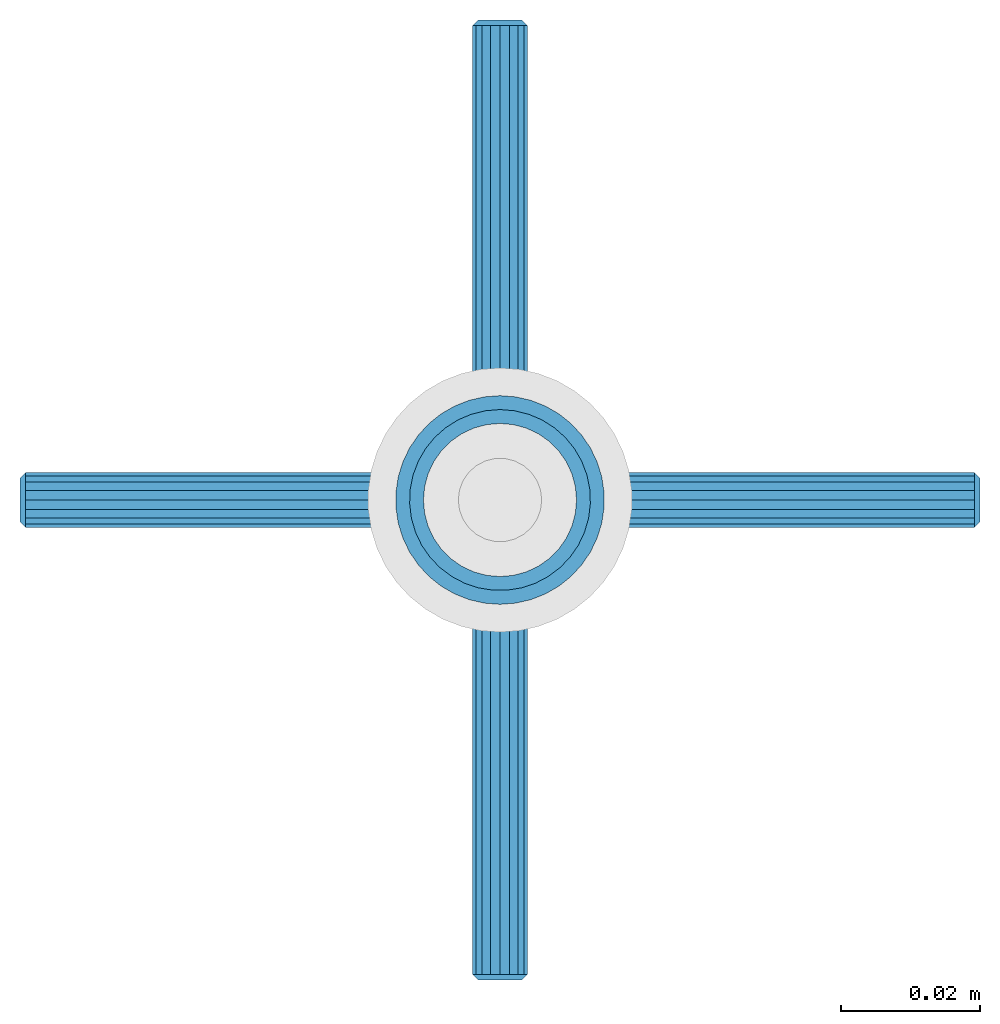
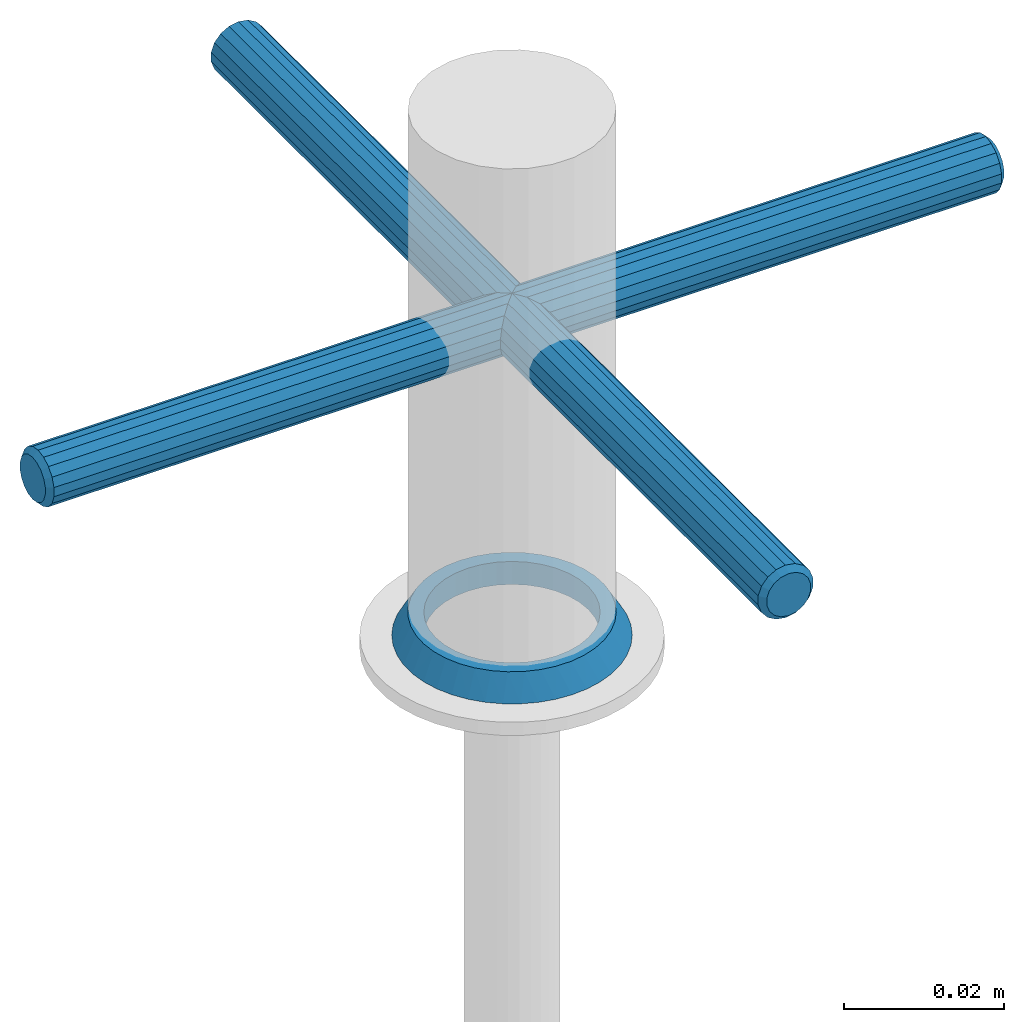
# One storey, part 3 of 3: 2 mechanical fasteners, 1 member, 2 elements without a shape of their own.
"""IFC4 building model written with IfcOpenShell, lengths in metres."""

from ifc_helpers import new_model, si_unit, direction, frame, origin_with_axes, place, context, subcontext, project, spatial, triangles, material, element, aggregate, save


model = new_model("IFC4")

# Units and contexts
model_context = context("Model", 3, precision=1e-05, world=origin_with_axes(), true_north=direction((0.0, 1.0)))
body_context = subcontext(model_context, "Body", "Model", "MODEL_VIEW")
ifc_project = project(units=[si_unit("LENGTHUNIT", "METRE"), si_unit("PLANEANGLEUNIT", "RADIAN"), si_unit("MASSUNIT", "GRAM", prefix="KILO"), si_unit("AREAUNIT", "SQUARE_METRE"), si_unit("TIMEUNIT", "SECOND"), si_unit("VOLUMEUNIT", "CUBIC_METRE")], contexts=[model_context])

# Site, building, storey
site_placement = place(None, origin_with_axes())
site = spatial("IfcSite", under=ifc_project, at=site_placement, CompositionType="ELEMENT")
building_placement = place(site_placement, origin_with_axes())
building = spatial("IfcBuilding", under=site, at=building_placement, CompositionType="ELEMENT")
storey_placement = place(building_placement, origin_with_axes())
storey = spatial("IfcBuildingStorey", under=building, at=storey_placement, Name="Geschoss 1", CompositionType="ELEMENT", Elevation=0.0)

# Member
ifc_material_1 = material()
member_placement = place(storey_placement, frame((8.149333, 6.0175, 0.02), z_axis=(0.0, 1.0, 0.0), x_axis=(0.0, 0.0, 1.0)))
element("IfcMember", 1, at=member_placement, inside=storey, material=ifc_material_1, PredefinedType="STUD", context=body_context, shape_type="Tessellation", body=[
    triangles([(0.0, -0.00191, -0.010833), (0.0035, 0.0, -0.011), (0.0, 0.0, -0.011), (0.0035, 0.00191, -0.010833), (0.0, 0.00191, -0.010833), (0.0035, 0.003762, -0.010337), (0.0, 0.003762, -0.010337), (0.0035, 0.0055, -0.009526), (0.0, 0.0055, -0.009526), (0.0035, 0.007071, -0.008426), (0.0, 0.007071, -0.008426), (0.0035, 0.008426, -0.007071), (0.0, 0.008426, -0.007071), (0.0035, 0.009526, -0.0055), (0.0, 0.009526, -0.0055), (0.0035, 0.010337, -0.003762), (0.0, 0.010337, -0.003762), (0.0035, 0.010833, -0.00191), (0.0, 0.010833, -0.00191), (0.0035, 0.011, 0.0), (0.0, 0.011, 0.0), (0.0035, 0.010833, 0.00191), (0.0, 0.010833, 0.00191), (0.0035, 0.010337, 0.003762), (0.0, 0.010337, 0.003762), (0.0035, 0.009526, 0.0055), (0.0, 0.009526, 0.0055), (0.0035, 0.008426, 0.007071), (0.0, 0.008426, 0.007071), (0.0035, 0.007071, 0.008426), (0.0, 0.007071, 0.008426), (0.0035, 0.0055, 0.009526), (0.0, 0.0055, 0.009526), (0.0035, 0.003762, 0.010337), (0.0, 0.003762, 0.010337), (0.0035, 0.00191, 0.010833), (0.0, 0.00191, 0.010833), (0.0035, 0.0, 0.011), (0.0, 0.0, 0.011), (0.0035, -0.00191, 0.010833), (0.0, -0.00191, 0.010833), (0.0035, -0.003762, 0.010337), (0.0, -0.003762, 0.010337), (0.0035, -0.0055, 0.009526), (0.0, -0.0055, 0.009526), (0.0035, -0.007071, 0.008426), (0.0, -0.007071, 0.008426), (0.0035, -0.008426, 0.007071), (0.0, -0.008426, 0.007071), (0.0035, -0.009526, 0.0055), (0.0, -0.009526, 0.0055), (0.0035, -0.010337, 0.003762), (0.0, -0.010337, 0.003762), (0.0035, -0.010833, 0.00191), (0.0, -0.010833, 0.00191), (0.0035, -0.011, 0.0), (0.0, -0.011, 0.0), (0.0035, -0.010833, -0.00191), (0.0, -0.010833, -0.00191), (0.0035, -0.010337, -0.003762), (0.0, -0.010337, -0.003762), (0.0035, -0.009526, -0.0055), (0.0, -0.009526, -0.0055), (0.0035, -0.008426, -0.007071), (0.0, -0.008426, -0.007071), (0.0035, -0.007071, -0.008426), (0.0, -0.007071, -0.008426), (0.0035, -0.0055, -0.009526), (0.0, -0.0055, -0.009526), (0.0035, -0.003762, -0.010337), (0.0, -0.003762, -0.010337), (0.0035, -0.00191, -0.010833), (0.0, 0.011727, -0.009352), (0.0, 0.01299, -0.0075), (0.0035, 0.011258, -0.0065), (0.0, 0.013963, -0.00548), (0.0035, 0.012155, -0.00461), (0.0, 0.014624, -0.003338), (0.0035, 0.012737, -0.0026), (0.0, 0.014958, -0.001121), (0.0035, 0.012989, -0.000523), (0.0, 0.014958, 0.001121), (0.0035, 0.012905, 0.001567), (0.0, 0.014624, 0.003338), (0.0035, 0.012487, 0.003617), (0.0, 0.013963, 0.00548), (0.0035, 0.011745, 0.005573), (0.0, 0.01299, 0.0075), (0.0035, 0.010699, 0.007385), (0.0, 0.011727, 0.009352), (0.0035, 0.009376, 0.009005), (0.0, 0.010203, 0.010996), (0.0035, 0.00781, 0.010393), (0.0, 0.00845, 0.012394), (0.0035, 0.006041, 0.011511), (0.0, 0.006508, 0.013515), (0.0035, 0.004117, 0.012331), (0.0, 0.004421, 0.014334), (0.0035, 0.002085, 0.012832), (0.0, 0.002236, 0.014832), (0.0035, 0.0, 0.013), (0.0, 0.0, 0.015), (0.0, -0.002236, 0.014832), (0.0035, 0.01007, -0.008222), (0.0, 0.010203, -0.010996), (0.0035, 0.008621, -0.009731), (0.0, 0.00845, -0.012394), (0.0035, 0.006948, -0.010987), (0.0, 0.006508, -0.013515), (0.0035, 0.005096, -0.01196), (0.0, 0.004421, -0.014334), (0.0035, 0.003111, -0.012622), (0.0, 0.002236, -0.014832), (0.0035, 0.001046, -0.012958), (0.0, 0.0, -0.015), (0.0035, -0.001046, -0.012958), (0.0, -0.002236, -0.014832), (0.0035, -0.003111, -0.012622), (0.0, -0.004421, -0.014334), (0.0035, -0.005096, -0.01196), (0.0, -0.006508, -0.013515), (0.0035, -0.006948, -0.010987), (0.0, -0.00845, -0.012394), (0.0035, -0.008621, -0.009731), (0.0, -0.010203, -0.010996), (0.0035, -0.01007, -0.008222), (0.0, -0.011727, -0.009352), (0.0035, -0.011258, -0.0065), (0.0, -0.01299, -0.0075), (0.0, -0.013963, -0.00548), (0.0035, -0.012155, -0.00461), (0.0, -0.014624, -0.003338), (0.0035, -0.012737, -0.0026), (0.0, -0.014958, -0.001121), (0.0035, -0.012989, -0.000523), (0.0, -0.014958, 0.001121), (0.0035, -0.012905, 0.001567), (0.0, -0.014624, 0.003338), (0.0035, -0.012487, 0.003617), (0.0, -0.013963, 0.00548), (0.0035, -0.011745, 0.005573), (0.0, -0.01299, 0.0075), (0.0035, -0.010699, 0.007385), (0.0, -0.011727, 0.009352), (0.0035, -0.009376, 0.009005), (0.0, -0.010203, 0.010996), (0.0035, -0.00781, 0.010393), (0.0, -0.00845, 0.012394), (0.0035, -0.006041, 0.011511), (0.0, -0.006508, 0.013515), (0.0035, -0.004117, 0.012331), (0.0, -0.004421, 0.014334), (0.0035, -0.002085, 0.012832)], [[1, 2, 3], [3, 2, 4], [3, 4, 5], [5, 4, 6], [5, 6, 7], [7, 6, 8], [7, 8, 9], [9, 8, 10], [9, 10, 11], [11, 10, 12], [11, 12, 13], [13, 12, 14], [13, 14, 15], [15, 14, 16], [15, 16, 17], [17, 16, 18], [17, 18, 19], [19, 18, 20], [19, 20, 21], [21, 20, 22], [21, 22, 23], [23, 22, 24], [23, 24, 25], [25, 24, 26], [25, 26, 27], [27, 26, 28], [27, 28, 29], [29, 28, 30], [29, 30, 31], [31, 30, 32], [31, 32, 33], [33, 32, 34], [33, 34, 35], [35, 34, 36], [35, 36, 37], [37, 36, 38], [37, 38, 39], [39, 38, 40], [39, 40, 41], [41, 40, 42], [41, 42, 43], [43, 42, 44], [43, 44, 45], [45, 44, 46], [45, 46, 47], [47, 46, 48], [47, 48, 49], [49, 48, 50], [49, 50, 51], [51, 50, 52], [51, 52, 53], [53, 52, 54], [53, 54, 55], [55, 54, 56], [55, 56, 57], [57, 56, 58], [57, 58, 59], [59, 58, 60], [59, 60, 61], [61, 60, 62], [61, 62, 63], [63, 62, 64], [63, 64, 65], [65, 64, 66], [65, 66, 67], [67, 66, 68], [67, 68, 69], [69, 68, 70], [69, 70, 71], [71, 70, 72], [71, 72, 1], [1, 72, 2], [73, 74, 75], [75, 74, 76], [75, 76, 77], [77, 76, 78], [77, 78, 79], [79, 78, 80], [79, 80, 81], [81, 80, 82], [81, 82, 83], [83, 82, 84], [83, 84, 85], [85, 84, 86], [85, 86, 87], [87, 86, 88], [87, 88, 89], [89, 88, 90], [89, 90, 91], [91, 90, 92], [91, 92, 93], [93, 92, 94], [93, 94, 95], [95, 94, 96], [95, 96, 97], [97, 96, 98], [97, 98, 99], [99, 98, 100], [99, 100, 101], [101, 100, 102], [101, 102, 103], [75, 104, 73], [73, 104, 105], [104, 106, 105], [105, 106, 107], [106, 108, 107], [107, 108, 109], [108, 110, 109], [109, 110, 111], [110, 112, 111], [111, 112, 113], [112, 114, 113], [113, 114, 115], [114, 116, 115], [115, 116, 117], [116, 118, 117], [117, 118, 119], [118, 120, 119], [119, 120, 121], [120, 122, 121], [121, 122, 123], [122, 124, 123], [123, 124, 125], [124, 126, 125], [125, 126, 127], [126, 128, 127], [127, 128, 129], [129, 128, 130], [130, 128, 131], [130, 131, 132], [132, 131, 133], [132, 133, 134], [134, 133, 135], [134, 135, 136], [136, 135, 137], [136, 137, 138], [138, 137, 139], [138, 139, 140], [140, 139, 141], [140, 141, 142], [142, 141, 143], [142, 143, 144], [144, 143, 145], [144, 145, 146], [146, 145, 147], [146, 147, 148], [148, 147, 149], [148, 149, 150], [150, 149, 151], [150, 151, 152], [152, 151, 153], [152, 153, 103], [103, 153, 101], [131, 128, 62], [62, 128, 126], [62, 126, 64], [64, 126, 124], [64, 124, 66], [66, 124, 122], [66, 122, 68], [68, 122, 120], [68, 120, 70], [70, 120, 118], [70, 118, 72], [72, 118, 116], [72, 116, 2], [2, 116, 114], [2, 114, 4], [4, 114, 112], [4, 112, 6], [6, 112, 110], [6, 110, 8], [8, 110, 108], [8, 108, 10], [10, 108, 106], [10, 106, 12], [12, 106, 104], [12, 104, 14], [14, 104, 75], [14, 75, 77], [62, 60, 131], [131, 60, 133], [60, 58, 133], [133, 58, 135], [58, 56, 135], [135, 56, 137], [56, 54, 137], [137, 54, 139], [54, 52, 139], [139, 52, 141], [52, 50, 141], [141, 50, 143], [50, 48, 143], [143, 48, 145], [48, 46, 145], [145, 46, 147], [46, 44, 147], [147, 44, 149], [44, 42, 149], [149, 42, 151], [42, 40, 151], [151, 40, 153], [40, 38, 153], [153, 38, 101], [101, 38, 99], [99, 38, 36], [99, 36, 97], [97, 36, 34], [97, 34, 95], [95, 34, 32], [95, 32, 93], [93, 32, 30], [93, 30, 91], [91, 30, 28], [91, 28, 89], [89, 28, 26], [89, 26, 87], [87, 26, 24], [87, 24, 85], [85, 24, 22], [85, 22, 83], [83, 22, 20], [83, 20, 81], [81, 20, 18], [81, 18, 79], [79, 18, 16], [79, 16, 77], [77, 16, 14], [76, 74, 15], [15, 74, 73], [15, 73, 13], [13, 73, 105], [13, 105, 11], [11, 105, 107], [11, 107, 9], [9, 107, 109], [9, 109, 7], [7, 109, 111], [7, 111, 5], [5, 111, 113], [5, 113, 3], [3, 113, 115], [3, 115, 117], [15, 17, 76], [76, 17, 78], [17, 19, 78], [78, 19, 80], [19, 21, 80], [80, 21, 82], [21, 23, 82], [82, 23, 84], [23, 25, 84], [84, 25, 86], [25, 27, 86], [86, 27, 88], [88, 27, 90], [90, 27, 29], [90, 29, 92], [92, 29, 31], [92, 31, 94], [94, 31, 33], [94, 33, 96], [96, 33, 35], [96, 35, 98], [98, 35, 37], [98, 37, 100], [100, 37, 39], [100, 39, 102], [102, 39, 103], [39, 41, 103], [103, 41, 152], [41, 43, 152], [152, 43, 150], [43, 45, 150], [150, 45, 148], [45, 47, 148], [148, 47, 146], [47, 49, 146], [146, 49, 144], [49, 51, 144], [144, 51, 142], [142, 51, 140], [140, 51, 53], [140, 53, 138], [138, 53, 55], [138, 55, 136], [136, 55, 57], [136, 57, 134], [134, 57, 59], [134, 59, 132], [132, 59, 61], [132, 61, 130], [130, 61, 63], [130, 63, 129], [129, 63, 127], [63, 65, 127], [127, 65, 125], [65, 67, 125], [125, 67, 123], [67, 69, 123], [123, 69, 121], [69, 71, 121], [121, 71, 119], [71, 1, 119], [119, 1, 117], [1, 3, 117]], closed=True),
])

# Mechanical fasteners
ifc_material_2 = material()
mechanical_fastener_1_placement = place(storey_placement, frame((8.220333, 6.0175, 0.068), z_axis=(0.0, 0.0, 1.0), x_axis=(-1.0, 0.0, 0.0)))
mechanical_fastener_1 = element("IfcMechanicalFastener", 2, at=mechanical_fastener_1_placement, inside=storey, material=ifc_material_2, PredefinedType="SCREW")
ifc_material_3 = material()
mechanical_fastener_2_placement = place(mechanical_fastener_1_placement, frame((0.002, 0.0, 0.0), z_axis=(0.0, 0.0, 1.0), x_axis=(1.0, 0.0, 0.0)))
mechanical_fastener_2 = element("IfcMechanicalFastener", 3, at=mechanical_fastener_2_placement, material=ifc_material_3, PredefinedType="NOTDEFINED", context=body_context, shape_type="Tessellation", body=[
    triangles([(0.1372, -0.001368, 0.003759), (0.138, 0.0, 0.0032), (0.1372, 0.0, 0.004), (0.138, 0.001094, 0.003007), (0.1372, 0.001368, 0.003759), (0.138, 0.002057, 0.002451), (0.1372, 0.002571, 0.003064), (0.138, 0.002771, 0.0016), (0.1372, 0.003464, 0.002), (0.138, 0.003151, 0.000556), (0.1372, 0.003939, 0.000695), (0.138, 0.003151, -0.000556), (0.1372, 0.003939, -0.000695), (0.138, 0.002771, -0.0016), (0.1372, 0.003464, -0.002), (0.138, 0.002057, -0.002451), (0.1372, 0.002571, -0.003064), (0.138, 0.001094, -0.003007), (0.1372, 0.001368, -0.003759), (0.138, 0.0, -0.0032), (0.1372, 0.0, -0.004), (0.138, -0.001094, -0.003007), (0.1372, -0.001368, -0.003759), (0.138, -0.002057, -0.002451), (0.1372, -0.002571, -0.003064), (0.138, -0.002771, -0.0016), (0.1372, -0.003464, -0.002), (0.138, -0.003151, -0.000556), (0.1372, -0.003939, -0.000695), (0.138, -0.003151, 0.000556), (0.1372, -0.003939, 0.000695), (0.138, -0.002771, 0.0016), (0.1372, -0.003464, 0.002), (0.138, -0.002057, 0.002451), (0.1372, -0.002571, 0.003064), (0.138, -0.001094, 0.003007), (0.0008, -0.001368, 0.003759), (0.0008, 0.0, 0.004), (0.0008, 0.001368, 0.003759), (0.0008, 0.002571, 0.003064), (0.0008, 0.003464, 0.002), (0.0008, 0.003939, 0.000695), (0.0008, 0.003939, -0.000695), (0.0008, 0.003464, -0.002), (0.0008, 0.002571, -0.003064), (0.0008, 0.001368, -0.003759), (0.0008, 0.0, -0.004), (0.0008, -0.001368, -0.003759), (0.0008, -0.002571, -0.003064), (0.0008, -0.003464, -0.002), (0.0008, -0.003939, -0.000695), (0.0008, -0.003939, 0.000695), (0.0008, -0.003464, 0.002), (0.0008, -0.002571, 0.003064), (0.0, -0.001094, 0.003007), (0.0, 0.0, 0.0032), (0.0, 0.001094, 0.003007), (0.0, 0.002057, 0.002451), (0.0, 0.002771, 0.0016), (0.0, 0.003151, 0.000556), (0.0, 0.003151, -0.000556), (0.0, 0.002771, -0.0016), (0.0, 0.002057, -0.002451), (0.0, 0.001094, -0.003007), (0.0, 0.0, -0.0032), (0.0, -0.001094, -0.003007), (0.0, -0.002057, -0.002451), (0.0, -0.002771, -0.0016), (0.0, -0.003151, -0.000556), (0.0, -0.003151, 0.000556), (0.0, -0.002771, 0.0016), (0.0, -0.002057, 0.002451)], [[1, 2, 3], [3, 2, 4], [3, 4, 5], [5, 4, 6], [5, 6, 7], [7, 6, 8], [7, 8, 9], [9, 8, 10], [9, 10, 11], [11, 10, 12], [11, 12, 13], [13, 12, 14], [13, 14, 15], [15, 14, 16], [15, 16, 17], [17, 16, 18], [17, 18, 19], [19, 18, 20], [19, 20, 21], [21, 20, 22], [21, 22, 23], [23, 22, 24], [23, 24, 25], [25, 24, 26], [25, 26, 27], [27, 26, 28], [27, 28, 29], [29, 28, 30], [29, 30, 31], [31, 30, 32], [31, 32, 33], [33, 32, 34], [33, 34, 35], [35, 34, 36], [35, 36, 1], [1, 36, 2], [30, 28, 32], [32, 28, 26], [32, 26, 34], [34, 26, 24], [34, 24, 36], [36, 24, 22], [36, 22, 2], [2, 22, 20], [2, 20, 4], [4, 20, 18], [4, 18, 6], [6, 18, 16], [6, 16, 8], [8, 16, 14], [8, 14, 10], [10, 14, 12], [37, 3, 38], [38, 3, 5], [38, 5, 39], [39, 5, 7], [39, 7, 40], [40, 7, 9], [40, 9, 41], [41, 9, 11], [41, 11, 42], [42, 11, 13], [42, 13, 43], [43, 13, 15], [43, 15, 44], [44, 15, 17], [44, 17, 45], [45, 17, 19], [45, 19, 46], [46, 19, 21], [46, 21, 47], [47, 21, 23], [47, 23, 48], [48, 23, 25], [48, 25, 49], [49, 25, 27], [49, 27, 50], [50, 27, 29], [50, 29, 51], [51, 29, 31], [51, 31, 52], [52, 31, 33], [52, 33, 53], [53, 33, 35], [53, 35, 54], [54, 35, 1], [54, 1, 37], [37, 1, 3], [55, 38, 56], [56, 38, 39], [56, 39, 57], [57, 39, 40], [57, 40, 58], [58, 40, 41], [58, 41, 59], [59, 41, 42], [59, 42, 60], [60, 42, 43], [60, 43, 61], [61, 43, 44], [61, 44, 62], [62, 44, 45], [62, 45, 63], [63, 45, 46], [63, 46, 64], [64, 46, 47], [64, 47, 65], [65, 47, 48], [65, 48, 66], [66, 48, 49], [66, 49, 67], [67, 49, 50], [67, 50, 68], [68, 50, 51], [68, 51, 69], [69, 51, 52], [69, 52, 70], [70, 52, 53], [70, 53, 71], [71, 53, 54], [71, 54, 72], [72, 54, 37], [72, 37, 55], [55, 37, 38], [60, 61, 59], [59, 61, 62], [59, 62, 58], [58, 62, 63], [58, 63, 57], [57, 63, 64], [57, 64, 56], [56, 64, 65], [56, 65, 55], [55, 65, 66], [55, 66, 72], [72, 66, 67], [72, 67, 71], [71, 67, 68], [71, 68, 70], [70, 68, 69]], closed=True),
])
aggregate(mechanical_fastener_1, [mechanical_fastener_2])

mechanical_fastener_3_placement = place(storey_placement, frame((8.149333, 6.0885, 0.068), z_axis=(0.0, 0.0, 1.0), x_axis=(0.0, -1.0, 0.0)))
mechanical_fastener_3 = element("IfcMechanicalFastener", 4, at=mechanical_fastener_3_placement, inside=storey, material=ifc_material_2, PredefinedType="SCREW")
mechanical_fastener_4_placement = place(mechanical_fastener_3_placement, frame((0.002, 0.0, 0.0), z_axis=(0.0, 0.0, 1.0), x_axis=(1.0, 0.0, 0.0)))
mechanical_fastener_4 = element("IfcMechanicalFastener", 5, at=mechanical_fastener_4_placement, material=ifc_material_3, PredefinedType="NOTDEFINED", context=body_context, shape_type="Tessellation", body=[
    triangles([(0.1372, -0.001368, 0.003759), (0.138, 0.0, 0.0032), (0.1372, 0.0, 0.004), (0.138, 0.001094, 0.003007), (0.1372, 0.001368, 0.003759), (0.138, 0.002057, 0.002451), (0.1372, 0.002571, 0.003064), (0.138, 0.002771, 0.0016), (0.1372, 0.003464, 0.002), (0.138, 0.003151, 0.000556), (0.1372, 0.003939, 0.000695), (0.138, 0.003151, -0.000556), (0.1372, 0.003939, -0.000695), (0.138, 0.002771, -0.0016), (0.1372, 0.003464, -0.002), (0.138, 0.002057, -0.002451), (0.1372, 0.002571, -0.003064), (0.138, 0.001094, -0.003007), (0.1372, 0.001368, -0.003759), (0.138, 0.0, -0.0032), (0.1372, 0.0, -0.004), (0.138, -0.001094, -0.003007), (0.1372, -0.001368, -0.003759), (0.138, -0.002057, -0.002451), (0.1372, -0.002571, -0.003064), (0.138, -0.002771, -0.0016), (0.1372, -0.003464, -0.002), (0.138, -0.003151, -0.000556), (0.1372, -0.003939, -0.000695), (0.138, -0.003151, 0.000556), (0.1372, -0.003939, 0.000695), (0.138, -0.002771, 0.0016), (0.1372, -0.003464, 0.002), (0.138, -0.002057, 0.002451), (0.1372, -0.002571, 0.003064), (0.138, -0.001094, 0.003007), (0.0008, -0.001368, 0.003759), (0.0008, 0.0, 0.004), (0.0008, 0.001368, 0.003759), (0.0008, 0.002571, 0.003064), (0.0008, 0.003464, 0.002), (0.0008, 0.003939, 0.000695), (0.0008, 0.003939, -0.000695), (0.0008, 0.003464, -0.002), (0.0008, 0.002571, -0.003064), (0.0008, 0.001368, -0.003759), (0.0008, 0.0, -0.004), (0.0008, -0.001368, -0.003759), (0.0008, -0.002571, -0.003064), (0.0008, -0.003464, -0.002), (0.0008, -0.003939, -0.000695), (0.0008, -0.003939, 0.000695), (0.0008, -0.003464, 0.002), (0.0008, -0.002571, 0.003064), (0.0, -0.001094, 0.003007), (0.0, 0.0, 0.0032), (0.0, 0.001094, 0.003007), (0.0, 0.002057, 0.002451), (0.0, 0.002771, 0.0016), (0.0, 0.003151, 0.000556), (0.0, 0.003151, -0.000556), (0.0, 0.002771, -0.0016), (0.0, 0.002057, -0.002451), (0.0, 0.001094, -0.003007), (0.0, 0.0, -0.0032), (0.0, -0.001094, -0.003007), (0.0, -0.002057, -0.002451), (0.0, -0.002771, -0.0016), (0.0, -0.003151, -0.000556), (0.0, -0.003151, 0.000556), (0.0, -0.002771, 0.0016), (0.0, -0.002057, 0.002451)], [[1, 2, 3], [3, 2, 4], [3, 4, 5], [5, 4, 6], [5, 6, 7], [7, 6, 8], [7, 8, 9], [9, 8, 10], [9, 10, 11], [11, 10, 12], [11, 12, 13], [13, 12, 14], [13, 14, 15], [15, 14, 16], [15, 16, 17], [17, 16, 18], [17, 18, 19], [19, 18, 20], [19, 20, 21], [21, 20, 22], [21, 22, 23], [23, 22, 24], [23, 24, 25], [25, 24, 26], [25, 26, 27], [27, 26, 28], [27, 28, 29], [29, 28, 30], [29, 30, 31], [31, 30, 32], [31, 32, 33], [33, 32, 34], [33, 34, 35], [35, 34, 36], [35, 36, 1], [1, 36, 2], [30, 28, 32], [32, 28, 26], [32, 26, 34], [34, 26, 24], [34, 24, 36], [36, 24, 22], [36, 22, 2], [2, 22, 20], [2, 20, 4], [4, 20, 18], [4, 18, 6], [6, 18, 16], [6, 16, 8], [8, 16, 14], [8, 14, 10], [10, 14, 12], [37, 3, 38], [38, 3, 5], [38, 5, 39], [39, 5, 7], [39, 7, 40], [40, 7, 9], [40, 9, 41], [41, 9, 11], [41, 11, 42], [42, 11, 13], [42, 13, 43], [43, 13, 15], [43, 15, 44], [44, 15, 17], [44, 17, 45], [45, 17, 19], [45, 19, 46], [46, 19, 21], [46, 21, 47], [47, 21, 23], [47, 23, 48], [48, 23, 25], [48, 25, 49], [49, 25, 27], [49, 27, 50], [50, 27, 29], [50, 29, 51], [51, 29, 31], [51, 31, 52], [52, 31, 33], [52, 33, 53], [53, 33, 35], [53, 35, 54], [54, 35, 1], [54, 1, 37], [37, 1, 3], [55, 38, 56], [56, 38, 39], [56, 39, 57], [57, 39, 40], [57, 40, 58], [58, 40, 41], [58, 41, 59], [59, 41, 42], [59, 42, 60], [60, 42, 43], [60, 43, 61], [61, 43, 44], [61, 44, 62], [62, 44, 45], [62, 45, 63], [63, 45, 46], [63, 46, 64], [64, 46, 47], [64, 47, 65], [65, 47, 48], [65, 48, 66], [66, 48, 49], [66, 49, 67], [67, 49, 50], [67, 50, 68], [68, 50, 51], [68, 51, 69], [69, 51, 52], [69, 52, 70], [70, 52, 53], [70, 53, 71], [71, 53, 54], [71, 54, 72], [72, 54, 37], [72, 37, 55], [55, 37, 38], [60, 61, 59], [59, 61, 62], [59, 62, 58], [58, 62, 63], [58, 63, 57], [57, 63, 64], [57, 64, 56], [56, 64, 65], [56, 65, 55], [55, 65, 66], [55, 66, 72], [72, 66, 67], [72, 67, 71], [71, 67, 68], [71, 68, 70], [70, 68, 69]], closed=True),
])
aggregate(mechanical_fastener_3, [mechanical_fastener_4])

save(model, "model.ifc")
